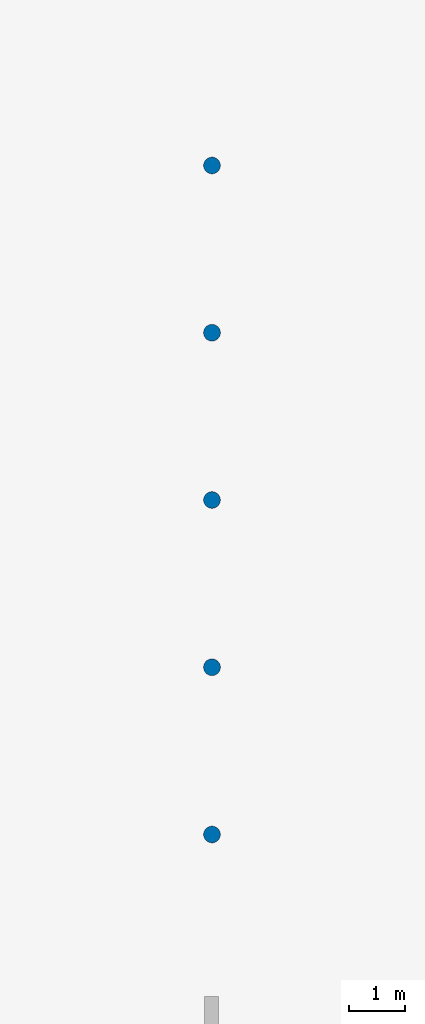
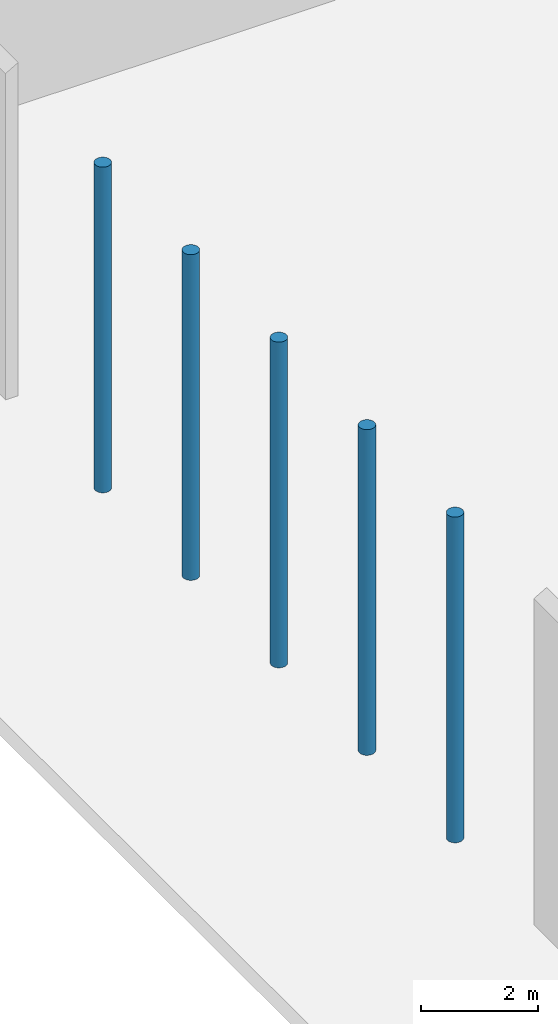
# One storey, part 1 of 39: 5 columns.
"""IFC2X3 building model written with IfcOpenShell, lengths in millimetres."""

from ifc_helpers import new_model, entity, si_unit, converted_unit, derived_unit, direction, frame, frame_2d, origin, place, context, subcontext, project, spatial, circle, extrude, source, transform, mapped, material, type_object, type_shapes, element, save


model = new_model("IFC2X3")

# Units and contexts
model_context = context("Model", 3, precision=1e-06, world=origin(), true_north=direction((2.0, 6.12303176911189e-17, 1.0)))
context_of_model = context(None, 3, precision=1e-06, world=origin(), true_north=direction((2.0, 6.12303176911189e-17, 1.0)))
body_context = subcontext(model_context, "Body", "Model", "MODEL_VIEW")
ifc_project = project(units=[si_unit("LENGTHUNIT", "METRE", prefix="MILLI"), si_unit("AREAUNIT", "SQUARE_METRE", prefix="MILLI"), si_unit("VOLUMEUNIT", "CUBIC_METRE", prefix="MILLI"), converted_unit("PLANEANGLEUNIT", "DEGREE", entity("IfcRatioMeasure", 0.0174532925199433), si_unit("PLANEANGLEUNIT", "RADIAN"), dimensions=[0, 0, 0, 0, 0, 0, 0]), si_unit("MASSUNIT", "GRAM", prefix="KILO"), si_unit("TIMEUNIT", "SECOND"), si_unit("THERMODYNAMICTEMPERATUREUNIT", "KELVIN"), derived_unit("THERMALTRANSMITTANCEUNIT", [(si_unit("MASSUNIT", "GRAM", prefix="KILO"), 1), (si_unit("THERMODYNAMICTEMPERATUREUNIT", "KELVIN"), -1), (si_unit("TIMEUNIT", "SECOND"), -3)]), derived_unit("VOLUMETRICFLOWRATEUNIT", [(si_unit("LENGTHUNIT", "METRE"), 3), (si_unit("TIMEUNIT", "SECOND"), -1)])], contexts=[model_context, context_of_model])

# Site, building, storey
site_placement = place(None, origin())
site = spatial("IfcSite", under=ifc_project, at=site_placement, CompositionType="ELEMENT")
building_placement = place(site_placement, origin())
building = spatial("IfcBuilding", under=site, at=building_placement, CompositionType="ELEMENT")
storey_placement = place(building_placement, frame((0.0, 0.0, 4000.0)))
storey = spatial("IfcBuildingStorey", under=building, at=storey_placement, Name="Level 2", CompositionType="ELEMENT", Elevation=4000.0)

# Columns
ifc_material = material(Name="Concrete - Cast-in-Place Concrete")
column_type_1 = type_object("IfcColumnType", Name="300mm", PredefinedType="COLUMN", material=ifc_material)
shared_shape_1 = source(origin(), body_context, "Body", "SweptSolid", [
    extrude(circle(Radius=149.999999999996, at=frame_2d((-93667.4247632616, -565.587677319665), x_axis=(1.0, 0.0))), origin(), (0.0, 0.0, 1.0), 6770.79056191359),
])
type_shapes(column_type_1, [shared_shape_1])
column_1_placement = place(storey_placement, frame((0.0, 0.0, 362.0)))
element("IfcColumn", 1, at=column_1_placement, inside=storey, type_object=column_type_1, material=ifc_material, Name="M_Concrete-Round-Column:300mm", ObjectType="300mm", context=body_context, shape_type="MappedRepresentation", body=[
    mapped(shared_shape_1, transform((0.0, 0.0, 0.0), scale=1.0)),
])
column_type_2 = type_object("IfcColumnType", Name="300mm", PredefinedType="COLUMN", material=ifc_material)
shared_shape_2 = source(origin(), body_context, "Body", "SweptSolid", [
    extrude(circle(Radius=149.999999999996, at=frame_2d((-93667.4247632616, 2434.41232268035), x_axis=(1.0, 0.0))), origin(), (0.0, 0.0, 1.0), 6770.79056191359),
])
type_shapes(column_type_2, [shared_shape_2])
column_2_placement = place(storey_placement, frame((0.0, 0.0, 362.0)))
element("IfcColumn", 2, at=column_2_placement, inside=storey, type_object=column_type_2, material=ifc_material, Name="M_Concrete-Round-Column:300mm", ObjectType="300mm", context=body_context, shape_type="MappedRepresentation", body=[
    mapped(shared_shape_2, transform((0.0, 0.0, 0.0), scale=1.0)),
])
column_type_3 = type_object("IfcColumnType", Name="300mm", PredefinedType="COLUMN", material=ifc_material)
shared_shape_3 = source(origin(), body_context, "Body", "SweptSolid", [
    extrude(circle(Radius=149.999999999996, at=frame_2d((-93667.4247632616, -3565.58767731967), x_axis=(1.0, 0.0))), origin(), (0.0, 0.0, 1.0), 6770.79056191359),
])
type_shapes(column_type_3, [shared_shape_3])
column_3_placement = place(storey_placement, frame((0.0, 0.0, 362.0)))
element("IfcColumn", 3, at=column_3_placement, inside=storey, type_object=column_type_3, material=ifc_material, Name="M_Concrete-Round-Column:300mm", ObjectType="300mm", context=body_context, shape_type="MappedRepresentation", body=[
    mapped(shared_shape_3, transform((0.0, 0.0, 0.0), scale=1.0)),
])
column_type_4 = type_object("IfcColumnType", Name="300mm", PredefinedType="COLUMN", material=ifc_material)
shared_shape_4 = source(origin(), body_context, "Body", "SweptSolid", [
    extrude(circle(Radius=149.999999999996, at=frame_2d((-93667.4247632616, -6565.58767731967), x_axis=(1.0, 0.0))), origin(), (0.0, 0.0, 1.0), 6770.79056191359),
])
type_shapes(column_type_4, [shared_shape_4])
column_4_placement = place(storey_placement, frame((0.0, 0.0, 362.0)))
element("IfcColumn", 4, at=column_4_placement, inside=storey, type_object=column_type_4, material=ifc_material, Name="M_Concrete-Round-Column:300mm", ObjectType="300mm", context=body_context, shape_type="MappedRepresentation", body=[
    mapped(shared_shape_4, transform((0.0, 0.0, 0.0), scale=1.0)),
])
column_type_5 = type_object("IfcColumnType", Name="300mm", PredefinedType="COLUMN", material=ifc_material)
shared_shape_5 = source(origin(), body_context, "Body", "SweptSolid", [
    extrude(circle(Radius=149.999999999996, at=frame_2d((-93667.4247632616, -9565.58767731967), x_axis=(1.0, 0.0))), origin(), (0.0, 0.0, 1.0), 6770.79056191359),
])
type_shapes(column_type_5, [shared_shape_5])
column_5_placement = place(storey_placement, frame((0.0, 0.0, 362.0)))
element("IfcColumn", 5, at=column_5_placement, inside=storey, type_object=column_type_5, material=ifc_material, Name="M_Concrete-Round-Column:300mm", ObjectType="300mm", context=body_context, shape_type="MappedRepresentation", body=[
    mapped(shared_shape_5, transform((0.0, 0.0, 0.0), scale=1.0)),
])

save(model, "model.ifc")
